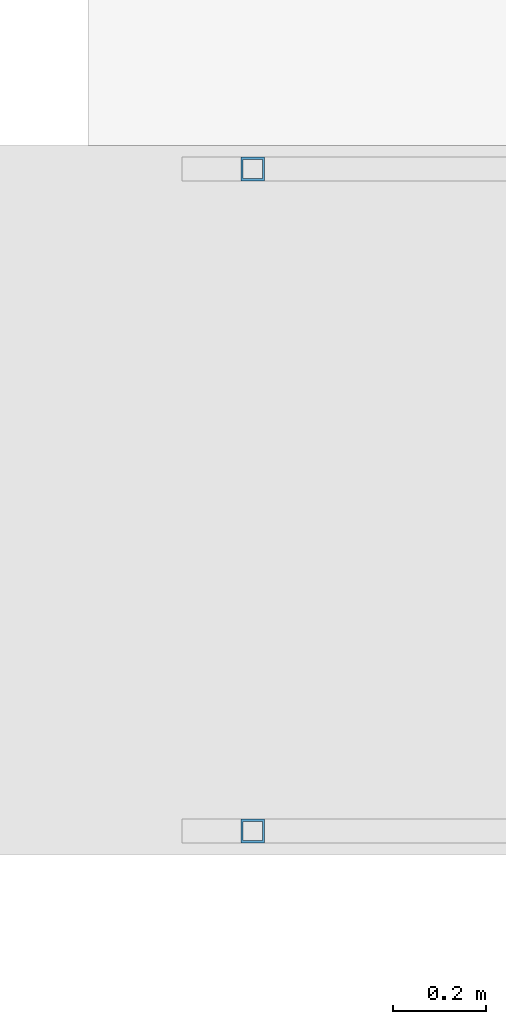
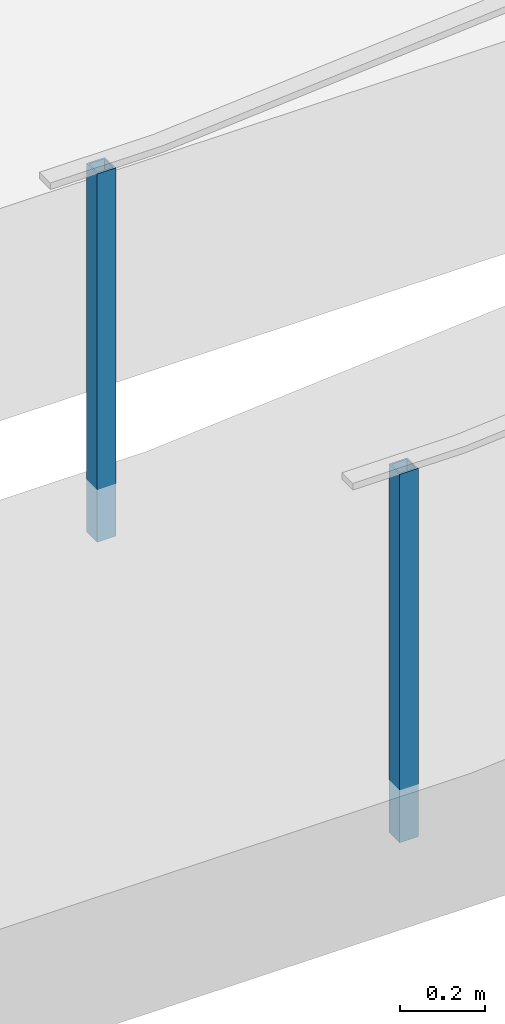
# One storey, part 872 of 1763: 2 columns, 2 elements without a shape of their own.
"""IFC2X3 building model written with IfcOpenShell, lengths in millimetres."""

import ifcopenshell
import ifcopenshell.guid

model = None  # the IFC model being written
_history = None  # IfcOwnerHistory: only IFC2X3 demands one
_inside = {}  # id of a spatial element -> (the spatial element, [elements in it])
_under = {}  # id of a project, library or spatial element -> (it, [spatial elements below it])
_declared = {}  # id of a project -> (the project, [libraries it declares])
_typed = {}  # id of a type object -> (the type object, [elements of that type])
_made_of = {}  # id of a material, layer set ... -> (it, [elements and type objects made of it])


def new_model(schema):
    """Start an empty IFC model of exactly this schema.

    Asked for "IFC4X3", IfcOpenShell would pick the latest addendum, in which some entities
    have other attributes; the version numbers below select the first issue.
    IFC2X3 requires an IfcOwnerHistory on every rooted entity: one is made here for all.
    """
    global model, _history
    if schema == "IFC4X3":
        model = ifcopenshell.file(schema_version=(4, 3, 0, 0))
    else:
        model = ifcopenshell.file(schema=schema)
    _inside.clear()
    _under.clear()
    _declared.clear()
    _typed.clear()
    _made_of.clear()
    _history = None
    if model.schema == "IFC2X3":
        org = make("IfcOrganization", Name="unknown")
        user = make(
            "IfcPersonAndOrganization",
            ThePerson=make("IfcPerson", FamilyName="unknown"),
            TheOrganization=org,
        )
        app = make(
            "IfcApplication",
            ApplicationDeveloper=org,
            Version="unknown",
            ApplicationFullName="unknown",
            ApplicationIdentifier="unknown",
        )
        _history = make(
            "IfcOwnerHistory",
            OwningUser=user,
            OwningApplication=app,
            ChangeAction="ADDED",
            CreationDate=0,
        )
    return model


def make(cls, **values):
    """One entity of the class cls with the attributes given. An attribute that is None is left unset."""
    return model.create_entity(
        cls, **{name: value for name, value in values.items() if value is not None}
    )


def rooted(cls, **values):
    """An entity with a GlobalId (a new one), such as an element, a storey or a relation."""
    return make(cls, GlobalId=ifcopenshell.guid.new(), OwnerHistory=_history, **values)


def si_unit(unit_type, name, prefix=None):
    """IfcSIUnit, for example si_unit("LENGTHUNIT", "METRE", prefix="MILLI")."""
    return make("IfcSIUnit", UnitType=unit_type, Prefix=prefix, Name=name)


def assignment(units):
    """IfcUnitAssignment: the units of a project."""
    return None if units is None else make("IfcUnitAssignment", Units=units)


def point(xyz):
    """IfcCartesianPoint."""
    return None if xyz is None else make("IfcCartesianPoint", Coordinates=xyz)


def direction(xyz):
    """IfcDirection."""
    return None if xyz is None else make("IfcDirection", DirectionRatios=xyz)


def frame(location, z_axis=None, x_axis=None):
    """IfcAxis2Placement3D, a coordinate frame: its origin and axes. An axis left out is left unset."""
    return make(
        "IfcAxis2Placement3D",
        Location=point(location),
        Axis=direction(z_axis),
        RefDirection=direction(x_axis),
    )


def origin_with_axes():
    """The frame at (0, 0, 0) with the z axis (0, 0, 1) and the x axis (1, 0, 0) written out."""
    return frame((0.0, 0.0, 0.0), z_axis=(0.0, 0.0, 1.0), x_axis=(1.0, 0.0, 0.0))


def place(relative_to, where):
    """IfcLocalPlacement: puts the frame where relative to a parent placement (None: the world)."""
    return make(
        "IfcLocalPlacement", PlacementRelTo=relative_to, RelativePlacement=where
    )


def context(
    kind, dimensions, precision=None, world=None, true_north=None, identifier=None
):
    """IfcGeometricRepresentationContext, for example the 3D "Model" context."""
    return make(
        "IfcGeometricRepresentationContext",
        ContextIdentifier=identifier,
        ContextType=kind,
        CoordinateSpaceDimension=dimensions,
        Precision=precision,
        WorldCoordinateSystem=world,
        TrueNorth=true_north,
    )


def subcontext(parent, identifier, kind, view, scale=None):
    """IfcGeometricRepresentationSubContext, for example "Body" below "Model"."""
    return make(
        "IfcGeometricRepresentationSubContext",
        ContextIdentifier=identifier,
        ContextType=kind,
        ParentContext=parent,
        TargetScale=scale,
        TargetView=view,
    )


def project(units=None, contexts=None):
    """IfcProject with its units and contexts."""
    return rooted(
        "IfcProject",
        Name="project",
        RepresentationContexts=contexts,
        UnitsInContext=assignment(units),
    )


def spatial(cls, under=None, at=None, **own):
    """A site, building, storey or space (cls), placed at a placement, below another one or the project."""
    s = rooted(cls, ObjectPlacement=at, **own)
    if under is not None:
        _under.setdefault(under.id(), (under, []))[1].append(s)
    return s


def faces_of(points, faces, orient=None, outer=None):
    """IfcFace entities. A face is a list of loops; a loop is a list of indices into points, from 0.

    orient and outer hold one flag for each loop. By default every Orientation is true, the
    first loop of a face is its IfcFaceOuterBound and the others are IfcFaceBound.
    """
    made = []
    for i, loops in enumerate(faces):
        bounds = []
        for j, loop in enumerate(loops):
            is_outer = j == 0 if outer is None else outer[i][j]
            bounds.append(
                make(
                    "IfcFaceOuterBound" if is_outer else "IfcFaceBound",
                    Bound=make("IfcPolyLoop", Polygon=[points[k] for k in loop]),
                    Orientation=True if orient is None else orient[i][j],
                )
            )
        made.append(make("IfcFace", Bounds=bounds))
    return made


def faceted_brep(points, faces, orient=None, outer=None, voids=None):
    """IfcFacetedBrep: a solid bounded by flat faces; with voids (closed shells), ...WithVoids."""
    shared = [point(p) for p in points]
    hull = make("IfcClosedShell", CfsFaces=faces_of(shared, faces, orient, outer))
    if voids is None:
        return make("IfcFacetedBrep", Outer=hull)
    return make(
        "IfcFacetedBrepWithVoids",
        Outer=hull,
        Voids=[
            make(cls, CfsFaces=faces_of(shared, fs, o, b)) for cls, fs, o, b in voids
        ],
    )


def shape(context_of_items, identifier, shape_type, items):
    """IfcShapeRepresentation: the items that make up one representation, for example the "Body"."""
    return make(
        "IfcShapeRepresentation",
        ContextOfItems=context_of_items,
        RepresentationIdentifier=identifier,
        RepresentationType=shape_type,
        Items=items,
    )


def material(Name=None, Category=None):
    """IfcMaterial."""
    return make("IfcMaterial", Name=Name, Category=Category)


def made_of(thing, what):
    """Note that an element or type object is made of a material, layer set ...; save() writes the relation."""
    if what is not None:
        _made_of.setdefault(what.id(), (what, []))[1].append(thing)
    return thing


def type_object(cls, material=None, **own):
    """A type object (cls), such as IfcWallType, which elements share."""
    return made_of(rooted(cls, **own), material)


def element(
    cls,
    number,
    at=None,
    inside=None,
    cuts=None,
    type_object=None,
    material=None,
    context=None,
    identifier="Body",
    shape_type=None,
    held_by="IfcProductDefinitionShape",
    body=None,
    shapes=None,
    **own,
):
    """One element of the class cls, such as IfcWall. Its Tag is "e" and its number.

    at: its placement. inside: the storey or other place that contains it. cuts: it is an
    opening in that element (IfcRelVoidsElement). A single representation is given by context,
    identifier, shape_type and body (its items); several are given by shapes. held_by: the class
    of the entity that holds the representations. save() writes the other relations.
    """
    e = rooted(cls, Tag="e%d" % number, ObjectPlacement=at, **own)
    if body is not None:
        shapes = [shape(context, identifier, shape_type, body)]
    if shapes is not None:
        e.Representation = make(held_by, Representations=shapes)
    if inside is not None:
        _inside.setdefault(inside.id(), (inside, []))[1].append(e)
    if cuts is not None:
        rooted(
            "IfcRelVoidsElement", RelatingBuildingElement=cuts, RelatedOpeningElement=e
        )
    if type_object is not None:
        _typed.setdefault(type_object.id(), (type_object, []))[1].append(e)
    return made_of(e, material)


def aggregate(whole, parts):
    """IfcRelAggregates: a whole, such as a stair, and the parts it consists of."""
    return rooted("IfcRelAggregates", RelatingObject=whole, RelatedObjects=parts)


def save(model, path):
    """Write the relations noted so far, then the file.

    IfcRelAggregates (storeys below a building ...), IfcRelContainedInSpatialStructure (elements
    in a storey), IfcRelDefinesByType, IfcRelAssociatesMaterial and IfcRelDeclares: one each for
    every whole, place, type object, material and project.
    """
    for whole, parts in _under.values():
        aggregate(whole, parts)
    for where, things in _inside.values():
        rooted(
            "IfcRelContainedInSpatialStructure",
            RelatedElements=things,
            RelatingStructure=where,
        )
    for kind, things in _typed.values():
        rooted("IfcRelDefinesByType", RelatedObjects=things, RelatingType=kind)
    for what, things in _made_of.values():
        rooted("IfcRelAssociatesMaterial", RelatedObjects=things, RelatingMaterial=what)
    for by, libraries in _declared.values():
        rooted("IfcRelDeclares", RelatingContext=by, RelatedDefinitions=libraries)
    model.write(path)


model = new_model("IFC2X3")

# Units and contexts
model_context = context("Model", 3, precision=1e-05, world=origin_with_axes())
body_context = subcontext(model_context, "Body", "Model", "MODEL_VIEW")
ifc_project = project(units=[si_unit("LENGTHUNIT", "METRE", prefix="MILLI"), si_unit("AREAUNIT", "SQUARE_METRE"), si_unit("VOLUMEUNIT", "CUBIC_METRE"), si_unit("MASSUNIT", "GRAM", prefix="KILO"), si_unit("TIMEUNIT", "SECOND"), si_unit("PLANEANGLEUNIT", "RADIAN"), si_unit("SOLIDANGLEUNIT", "STERADIAN"), si_unit("THERMODYNAMICTEMPERATUREUNIT", "DEGREE_CELSIUS"), si_unit("LUMINOUSINTENSITYUNIT", "LUMEN")], contexts=[model_context])

# Site, building, storey
site_placement = place(None, origin_with_axes())
site = spatial("IfcSite", under=ifc_project, at=site_placement, CompositionType="ELEMENT")
building_placement = place(site_placement, origin_with_axes())
building = spatial("IfcBuilding", under=site, at=building_placement, Name="Undefined", CompositionType="ELEMENT")
storey_placement = place(building_placement, origin_with_axes())
storey = spatial("IfcBuildingStorey", under=building, at=storey_placement, Name="Undefined", CompositionType="ELEMENT", Elevation=0.0)

# Assembly, column
assembly_1_placement = place(storey_placement, origin_with_axes())
assembly_1 = element("IfcElementAssembly", 1, at=assembly_1_placement, inside=storey, Name="HANDRAIL", AssemblyPlace="NOTDEFINED", PredefinedType="RIGID_FRAME")
ifc_material = material()
column_type = type_object("IfcColumnType", Name="2X2X3/16 SQUARE TUBE SS", PredefinedType="NOTDEFINED")
column_1_placement = place(assembly_1_placement, frame((-81306.4084002103, -16535.4002326199, 4040.14931433106), z_axis=(-0.999999999891248, 0.0, 1.47479999968709e-05), x_axis=(1.47479999970212e-05, 0.0, 0.999999999891248)))
column_1 = element("IfcColumn", 2, at=column_1_placement, type_object=column_type, material=ifc_material, Name="POST TUBE", ObjectType="2X2X3/16 SQUARE TUBE SS", context=body_context, shape_type="Brep", body=[
    faceted_brep([(0.0, 20.6375000000007, -20.6374999999971), (0.0, -20.6375000000007, -20.6374999999971), (1057.27821068622, -20.6375000000007, -20.6375000025437), (1057.27821068622, 20.6375000000007, -20.6375000025437), (0.0, -20.6375000000007, 20.6374999999971), (1057.27751932987, -20.6375000000007, 20.6374999977415), (0.0, 20.6375000000007, 20.6374999999971), (1057.27751932987, 20.6375000000007, 20.6374999977415), (-1.45519152283669e-11, 25.4000000000015, -25.3999999999869), (1.45519152283669e-11, 25.4000000000015, 25.3999999999796), (1057.27743955799, 25.4000000000015, 25.3999999977677), (1057.2782904581, 25.4000000000015, -25.4000000025844), (0.0, -25.4000000000015, 25.3999999999942), (1057.27743955799, -25.4000000000015, 25.3999999977677), (-1.45519152283669e-11, -25.4000000000015, -25.3999999999869), (1057.2782904581, -25.4000000000015, -25.4000000025844)], [[[0, 1, 2, 3]], [[1, 4, 5, 2]], [[4, 6, 7, 5]], [[6, 0, 3, 7]], [[8, 9, 10, 11]], [[9, 12, 13, 10]], [[12, 14, 15, 13]], [[14, 8, 11, 15]], [[13, 15, 11, 10], [5, 7, 3, 2]], [[14, 12, 9, 8], [6, 4, 1, 0]]]),
])
aggregate(assembly_1, [column_1])

assembly_2_placement = place(storey_placement, origin_with_axes())
assembly_2 = element("IfcElementAssembly", 3, at=assembly_2_placement, inside=storey, Name="HANDRAIL", AssemblyPlace="NOTDEFINED", PredefinedType="RIGID_FRAME")
column_2_placement = place(assembly_2_placement, frame((-81306.4084002103, -17957.80011631, 4040.14931433106), z_axis=(-0.999999999891248, 0.0, 1.47479999968709e-05), x_axis=(1.47479999970212e-05, 0.0, 0.999999999891248)))
column_2 = element("IfcColumn", 4, at=column_2_placement, type_object=column_type, material=ifc_material, Name="POST TUBE", ObjectType="2X2X3/16 SQUARE TUBE SS", context=body_context, shape_type="Brep", body=[
    faceted_brep([(0.0, 20.6375000000007, -20.6374999999971), (0.0, -20.6375000000007, -20.6374999999971), (1057.27821068622, -20.6375000000007, -20.6375000025437), (1057.27821068622, 20.6375000000007, -20.6375000025437), (0.0, -20.6375000000007, 20.6374999999971), (1057.27751932987, -20.6375000000007, 20.6374999977415), (0.0, 20.6375000000007, 20.6374999999971), (1057.27751932987, 20.6375000000007, 20.6374999977415), (-1.45519152283669e-11, 25.4000000000015, -25.3999999999869), (1.45519152283669e-11, 25.4000000000015, 25.3999999999796), (1057.27743955799, 25.4000000000015, 25.3999999977677), (1057.2782904581, 25.4000000000015, -25.4000000025844), (0.0, -25.4000000000015, 25.3999999999942), (1057.27743955799, -25.4000000000015, 25.3999999977677), (-1.45519152283669e-11, -25.4000000000015, -25.3999999999869), (1057.2782904581, -25.4000000000015, -25.4000000025844)], [[[0, 1, 2, 3]], [[1, 4, 5, 2]], [[4, 6, 7, 5]], [[6, 0, 3, 7]], [[8, 9, 10, 11]], [[9, 12, 13, 10]], [[12, 14, 15, 13]], [[14, 8, 11, 15]], [[13, 15, 11, 10], [5, 7, 3, 2]], [[14, 12, 9, 8], [6, 4, 1, 0]]]),
])
aggregate(assembly_2, [column_2])

save(model, "model.ifc")
